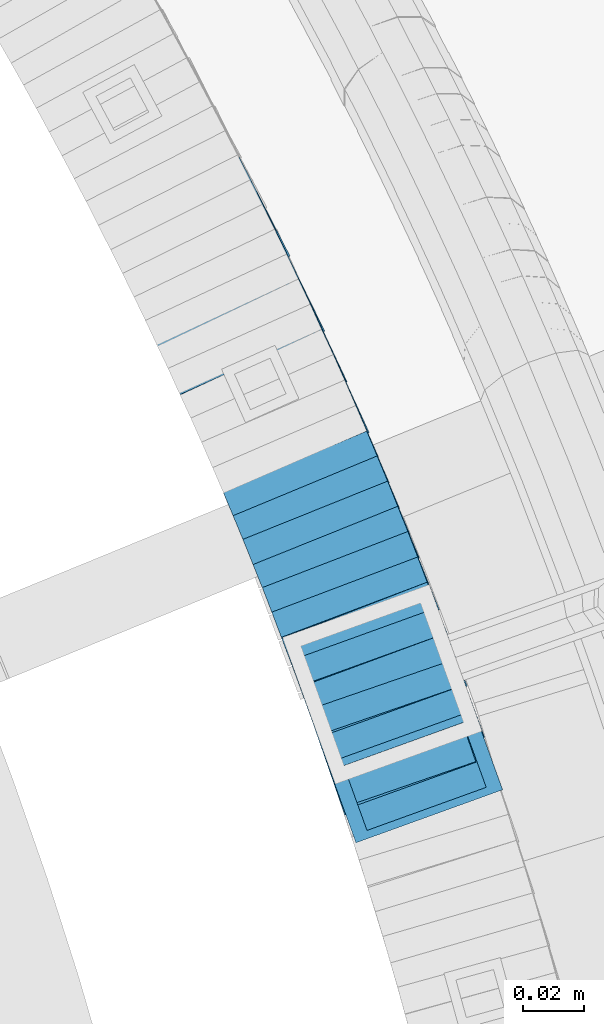
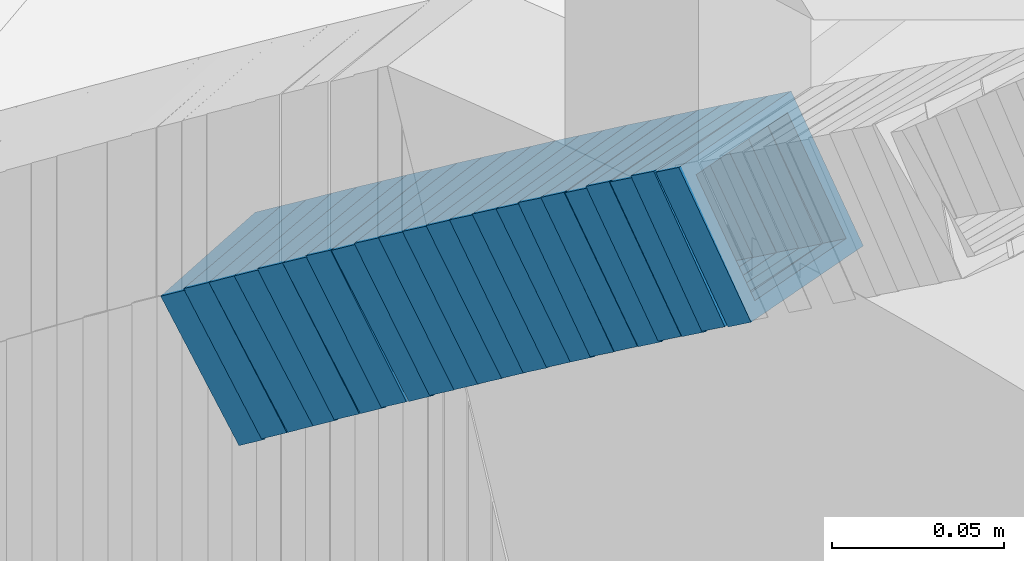
# One storey, part 800 of 975: 22 members.
"""IFC2X3 building model written with IfcOpenShell, lengths in millimetres."""

from ifc_helpers import new_model, si_unit, frame, origin_with_axes, place, context, subcontext, project, spatial, faceted_brep, material, type_object, element, save


model = new_model("IFC2X3")

# Units and contexts
model_context = context("Model", 3, precision=1e-05, world=origin_with_axes())
body_context = subcontext(model_context, "Body", "Model", "MODEL_VIEW")
ifc_project = project(units=[si_unit("LENGTHUNIT", "METRE", prefix="MILLI"), si_unit("AREAUNIT", "SQUARE_METRE"), si_unit("VOLUMEUNIT", "CUBIC_METRE"), si_unit("MASSUNIT", "GRAM", prefix="KILO"), si_unit("TIMEUNIT", "SECOND"), si_unit("PLANEANGLEUNIT", "RADIAN"), si_unit("SOLIDANGLEUNIT", "STERADIAN"), si_unit("THERMODYNAMICTEMPERATUREUNIT", "DEGREE_CELSIUS"), si_unit("LUMINOUSINTENSITYUNIT", "LUMEN")], contexts=[model_context])

# Site, building, storey
site_placement = place(None, origin_with_axes())
site = spatial("IfcSite", under=ifc_project, at=site_placement, CompositionType="ELEMENT")
building_placement = place(site_placement, origin_with_axes())
building = spatial("IfcBuilding", under=site, at=building_placement, Name="Undefined", CompositionType="ELEMENT")
storey_placement = place(building_placement, origin_with_axes())
storey = spatial("IfcBuildingStorey", under=building, at=storey_placement, Name="Undefined", CompositionType="ELEMENT", Elevation=0.0)

# Members
ifc_material = material()
member_type = type_object("IfcMemberType", Name="HSS2X2X.188_TUBES", PredefinedType="NOTDEFINED")
member_1_placement = place(storey_placement, frame((36056.3723395032, 3855.56364250104, 2169.06319573244), z_axis=(0.940453312518291, 0.339922883862463, 1.97324879991356e-10), x_axis=(0.285545985945671, -0.790010561850313, 0.542537373897198)))
element("IfcMember", 1, at=member_1_placement, inside=storey, type_object=member_type, material=ifc_material, Name="WALL", ObjectType="HSS2X2X.188_TUBES", context=body_context, shape_type="Brep", body=[
    faceted_brep([(0.0, 20.6374999999753, -20.6375000000298), (0.0, -20.6375000000153, -20.6375000000153), (10.5118980208099, -20.6374999999875, -20.637499999968), (10.5118980207899, 20.6374999999921, -20.6375000000189), (0.0, -20.6374999999825, 20.6375000000335), (10.5118980208281, -20.6374999999784, 20.637500000099), (0.0, 20.6375000000116, 20.6375000000189), (10.5118980208063, 20.6375000000016, 20.6375000000335), (0.0, 25.3999999999724, -25.4000000000342), (0.0, 25.400000000016, 25.4000000000196), (10.5118980208063, 25.4000000000005, 25.4000000000306), (10.5118980207862, 25.3999999999896, -25.4000000000378), (0.0, -25.399999999976, 25.4000000000378), (10.5118980208317, -25.3999999999746, 25.4000000001033), (0.0, -25.400000000016, -25.4000000000196), (10.5118980208135, -25.3999999999855, -25.3999999999724)], [[[0, 1, 2, 3]], [[1, 4, 5, 2]], [[4, 6, 7, 5]], [[6, 0, 3, 7]], [[8, 9, 10, 11]], [[9, 12, 13, 10]], [[12, 14, 15, 13]], [[14, 8, 11, 15]], [[13, 15, 11, 10], [5, 7, 3, 2]], [[14, 12, 9, 8], [6, 4, 1, 0]]]),
])
member_2_placement = place(storey_placement, frame((36050.4690767219, 3872.36681990624, 2157.57332488823), z_axis=(0.938152292840694, 0.346222869605329, 2.00598151423037e-10), x_axis=(0.292063186936097, -0.79139702382609, 0.537019408881968)))
element("IfcMember", 2, at=member_2_placement, inside=storey, type_object=member_type, material=ifc_material, Name="WALL", ObjectType="HSS2X2X.188_TUBES", context=body_context, shape_type="Brep", body=[
    faceted_brep([(0.0, 20.6374999999753, -20.6375000000298), (0.0, -20.6375000000153, -20.6375000000153), (10.6061303028146, -20.6374999999571, -20.6374999999643), (10.6061303027491, 20.6374999999971, -20.6375000000007), (0.0, -20.6374999999825, 20.6375000000335), (10.6061303027855, -20.6374999999825, 20.6375000000116), (0.0, 20.6375000000116, 20.6375000000189), (10.6061303027236, 20.637499999968, 20.6374999999716), (0.0, 25.3999999999724, -25.4000000000342), (0.0, 25.400000000016, 25.4000000000196), (10.6061303027163, 25.3999999999651, 25.3999999999651), (10.6061303027454, 25.3999999999942, -25.4000000000051), (0.0, -25.399999999976, 25.4000000000378), (10.6061303027891, -25.3999999999796, 25.4000000000124), (0.0, -25.400000000016, -25.4000000000196), (10.6061303028182, -25.3999999999505, -25.3999999999542)], [[[0, 1, 2, 3]], [[1, 4, 5, 2]], [[4, 6, 7, 5]], [[6, 0, 3, 7]], [[8, 9, 10, 11]], [[9, 12, 13, 10]], [[12, 14, 15, 13]], [[14, 8, 11, 15]], [[13, 15, 11, 10], [5, 7, 3, 2]], [[14, 12, 9, 8], [6, 4, 1, 0]]]),
])
member_3_placement = place(storey_placement, frame((36053.1413653361, 3864.30582773632, 2163.32011987454), z_axis=(0.945253332455169, 0.326337459514532, 3.89617525797802e-10), x_axis=(0.274687234983439, -0.795645785953005, 0.53990249696809)))
element("IfcMember", 3, at=member_3_placement, inside=storey, type_object=member_type, material=ifc_material, Name="WALL", ObjectType="HSS2X2X.188_TUBES", context=body_context, shape_type="Brep", body=[
    faceted_brep([(0.0, 20.6374999999753, -20.6375000000298), (0.0, -20.6375000000153, -20.6375000000153), (10.5550935571373, -20.6374999999935, -20.6374999999753), (10.5550935571373, 20.6375000000025, -20.6374999999862), (0.0, -20.6374999999825, 20.6375000000335), (10.5550935571027, -20.6374999999989, 20.6374999999862), (0.0, 20.6375000000116, 20.6375000000189), (10.5550935571027, 20.6374999999953, 20.6374999999716), (0.0, 25.3999999999724, -25.4000000000342), (0.0, 25.400000000016, 25.4000000000196), (10.5550935570991, 25.3999999999924, 25.3999999999651), (10.5550935571373, 25.3999999999996, -25.3999999999905), (0.0, -25.399999999976, 25.4000000000378), (10.5550935571009, -25.3999999999996, 25.3999999999833), (0.0, -25.400000000016, -25.4000000000196), (10.5550935571428, -25.3999999999905, -25.3999999999724)], [[[0, 1, 2, 3]], [[1, 4, 5, 2]], [[4, 6, 7, 5]], [[6, 0, 3, 7]], [[8, 9, 10, 11]], [[9, 12, 13, 10]], [[12, 14, 15, 13]], [[14, 8, 11, 15]], [[13, 15, 11, 10], [5, 7, 3, 2]], [[14, 12, 9, 8], [6, 4, 1, 0]]]),
])
member_4_placement = place(storey_placement, frame((36047.3723395032, 3880.66364250103, 2151.96319573233), z_axis=(0.940453312518291, 0.339922883862463, 1.97324879991356e-10), x_axis=(0.285545985945671, -0.790010561850313, 0.542537373897198)))
element("IfcMember", 4, at=member_4_placement, inside=storey, type_object=member_type, material=ifc_material, Name="WALL", ObjectType="HSS2X2X.188_TUBES", context=body_context, shape_type="Brep", body=[
    faceted_brep([(0.0, 20.6374999999753, -20.6375000000298), (0.0, -20.6375000000153, -20.6375000000153), (10.5118980208099, -20.6374999999875, -20.637499999968), (10.5118980207899, 20.6374999999921, -20.6375000000189), (0.0, -20.6374999999825, 20.6375000000335), (10.5118980208281, -20.6374999999784, 20.637500000099), (0.0, 20.6375000000116, 20.6375000000189), (10.5118980208063, 20.6375000000016, 20.6375000000335), (0.0, 25.3999999999724, -25.4000000000342), (0.0, 25.400000000016, 25.4000000000196), (10.5118980208063, 25.4000000000005, 25.4000000000306), (10.5118980207862, 25.3999999999896, -25.4000000000378), (0.0, -25.399999999976, 25.4000000000378), (10.5118980208317, -25.3999999999746, 25.4000000001033), (0.0, -25.400000000016, -25.4000000000196), (10.5118980208135, -25.3999999999855, -25.3999999999724)], [[[0, 1, 2, 3]], [[1, 4, 5, 2]], [[4, 6, 7, 5]], [[6, 0, 3, 7]], [[8, 9, 10, 11]], [[9, 12, 13, 10]], [[12, 14, 15, 13]], [[14, 8, 11, 15]], [[13, 15, 11, 10], [5, 7, 3, 2]], [[14, 12, 9, 8], [6, 4, 1, 0]]]),
])
member_5_placement = place(storey_placement, frame((36044.6056120165, 3888.63404795882, 2146.2138164465), z_axis=(0.933055569354949, 0.359732267798863, 2.02075170818717e-10), x_axis=(0.302885839104442, -0.785610145271108, 0.5395154011862)))
element("IfcMember", 5, at=member_5_placement, inside=storey, type_object=member_type, material=ifc_material, Name="WALL", ObjectType="HSS2X2X.188_TUBES", context=body_context, shape_type="Brep", body=[
    faceted_brep([(0.0, 20.6374999999753, -20.6375000000298), (0.0, -20.6375000000153, -20.6375000000153), (10.5744976239494, -20.6375000000207, -20.6375000000335), (10.5744976239657, 20.6375000000098, -20.637500000008), (0.0, -20.6374999999825, 20.6375000000335), (10.5744976239639, -20.6375000000244, 20.6374999999753), (0.0, 20.6375000000116, 20.6375000000189), (10.5744976239803, 20.6374999999989, 20.6374999999935), (0.0, 25.3999999999724, -25.4000000000342), (0.0, 25.400000000016, 25.4000000000196), (10.5744976239857, 25.4000000000051, 25.4000000000015), (10.5744976239675, 25.4000000000124, -25.4000000000051), (0.0, -25.399999999976, 25.4000000000378), (10.5744976239639, -25.4000000000287, 25.3999999999724), (0.0, -25.400000000016, -25.4000000000196), (10.5744976239494, -25.4000000000215, -25.4000000000378)], [[[0, 1, 2, 3]], [[1, 4, 5, 2]], [[4, 6, 7, 5]], [[6, 0, 3, 7]], [[8, 9, 10, 11]], [[9, 12, 13, 10]], [[12, 14, 15, 13]], [[14, 8, 11, 15]], [[13, 15, 11, 10], [5, 7, 3, 2]], [[14, 12, 9, 8], [6, 4, 1, 0]]]),
])
member_6_placement = place(storey_placement, frame((36038.2438297402, 3905.29429573805, 2134.80473457044), z_axis=(0.933055569354949, 0.359732267798863, 2.02075170818717e-10), x_axis=(0.304430731987314, -0.789617209966803, 0.532753780977583)))
element("IfcMember", 6, at=member_6_placement, inside=storey, type_object=member_type, material=ifc_material, Name="WALL", ObjectType="HSS2X2X.188_TUBES", context=body_context, shape_type="Brep", body=[
    faceted_brep([(0.0, 20.6374999999753, -20.6375000000298), (0.0, -20.6375000000153, -20.6375000000153), (10.5118980208099, -20.6374999999875, -20.637499999968), (10.5118980207899, 20.6374999999921, -20.6375000000189), (0.0, -20.6374999999825, 20.6375000000335), (10.5118980208281, -20.6374999999784, 20.637500000099), (0.0, 20.6375000000116, 20.6375000000189), (10.5118980208063, 20.6375000000016, 20.6375000000335), (0.0, 25.3999999999724, -25.4000000000342), (0.0, 25.400000000016, 25.4000000000196), (10.5118980208063, 25.4000000000005, 25.4000000000306), (10.5118980207862, 25.3999999999896, -25.4000000000378), (0.0, -25.399999999976, 25.4000000000378), (10.5118980208317, -25.3999999999746, 25.4000000001033), (0.0, -25.400000000016, -25.4000000000196), (10.5118980208135, -25.3999999999855, -25.3999999999724)], [[[0, 1, 2, 3]], [[1, 4, 5, 2]], [[4, 6, 7, 5]], [[6, 0, 3, 7]], [[8, 9, 10, 11]], [[9, 12, 13, 10]], [[12, 14, 15, 13]], [[14, 8, 11, 15]], [[13, 15, 11, 10], [5, 7, 3, 2]], [[14, 12, 9, 8], [6, 4, 1, 0]]]),
])
member_7_placement = place(storey_placement, frame((36035.3513403643, 3913.00453572634, 2129.25354307798), z_axis=(0.927694411235425, 0.373340433602575, 2.94433448289055e-10), x_axis=(0.313759664807495, -0.779645228521997, 0.541948512667736)))
element("IfcMember", 7, at=member_7_placement, inside=storey, type_object=member_type, material=ifc_material, Name="WALL", ObjectType="HSS2X2X.188_TUBES", context=body_context, shape_type="Brep", body=[
    faceted_brep([(0.0, 20.6374999999753, -20.6375000000298), (0.0, -20.6375000000153, -20.6375000000153), (10.5190303735253, -20.6375000000171, -20.6375000000444), (10.5190303734962, 20.6374999999607, -20.6375000000808), (0.0, -20.6374999999825, 20.6375000000335), (10.5190303735744, -20.6374999999844, 20.6375000000407), (0.0, 20.6375000000116, 20.6375000000189), (10.5190303735435, 20.6374999999916, 20.6375000000044), (0.0, 25.3999999999724, -25.4000000000342), (0.0, 25.400000000016, 25.4000000000196), (10.5190303735435, 25.3999999999942, 25.4000000000124), (10.5190303734835, 25.3999999999523, -25.4000000000924), (0.0, -25.399999999976, 25.4000000000378), (10.5190303735853, -25.399999999976, 25.400000000056), (0.0, -25.400000000016, -25.4000000000196), (10.5190303735235, -25.4000000000196, -25.4000000000451)], [[[0, 1, 2, 3]], [[1, 4, 5, 2]], [[4, 6, 7, 5]], [[6, 0, 3, 7]], [[8, 9, 10, 11]], [[9, 12, 13, 10]], [[12, 14, 15, 13]], [[14, 8, 11, 15]], [[13, 15, 11, 10], [5, 7, 3, 2]], [[14, 12, 9, 8], [6, 4, 1, 0]]]),
])
member_8_placement = place(storey_placement, frame((36041.4128976851, 3896.82431602697, 2140.60556520589), z_axis=(0.935388263671988, 0.353622392086111, -1.27792191051413e-10), x_axis=(0.296464132970014, -0.78419544892014, 0.545111470944502)))
element("IfcMember", 8, at=member_8_placement, inside=storey, type_object=member_type, material=ifc_material, Name="WALL", ObjectType="HSS2X2X.188_TUBES", context=body_context, shape_type="Brep", body=[
    faceted_brep([(0.0, 20.6374999999753, -20.6375000000298), (0.0, -20.6375000000153, -20.6375000000153), (10.4565768777284, -20.6375000000116, -20.6375000000407), (10.456576877752, 20.6375000000007, -20.6374999999971), (0.0, -20.6374999999825, 20.6375000000335), (10.4565768777265, -20.6375000000126, 20.6374999999389), (0.0, 20.6375000000116, 20.6375000000189), (10.4565768777502, 20.6374999999989, 20.6374999999825), (0.0, 25.3999999999724, -25.4000000000342), (0.0, 25.400000000016, 25.4000000000196), (10.456576877752, 25.3999999999992, 25.3999999999796), (10.4565768777538, 25.4000000000015, -25.3999999999942), (0.0, -25.399999999976, 25.4000000000378), (10.4565768777247, -25.4000000000142, 25.399999999936), (0.0, -25.400000000016, -25.4000000000196), (10.4565768777265, -25.4000000000115, -25.4000000000451)], [[[0, 1, 2, 3]], [[1, 4, 5, 2]], [[4, 6, 7, 5]], [[6, 0, 3, 7]], [[8, 9, 10, 11]], [[9, 12, 13, 10]], [[12, 14, 15, 13]], [[14, 8, 11, 15]], [[13, 15, 11, 10], [5, 7, 3, 2]], [[14, 12, 9, 8], [6, 4, 1, 0]]]),
])
member_9_placement = place(storey_placement, frame((36028.8032098126, 3929.41023413412, 2117.81749797898), z_axis=(0.923742113500945, 0.383015022870914, -4.53592292615214e-11), x_axis=(0.323941772034664, -0.781271332083476, 0.533551154056996)))
element("IfcMember", 9, at=member_9_placement, inside=storey, type_object=member_type, material=ifc_material, Name="WALL", ObjectType="HSS2X2X.188_TUBES", context=body_context, shape_type="Brep", body=[
    faceted_brep([(0.0, 20.6374999999753, -20.6375000000298), (0.0, -20.6375000000153, -20.6375000000153), (10.5019045891313, -20.6375000000226, -20.6375000000371), (10.5019045891022, 20.6374999999662, -20.6375000000771), (0.0, -20.6374999999825, 20.6375000000335), (10.5019045891859, -20.6374999999771, 20.6375000000444), (0.0, 20.6375000000116, 20.6375000000189), (10.5019045891568, 20.6375000000098, 20.637500000008), (0.0, 25.3999999999724, -25.4000000000342), (0.0, 25.400000000016, 25.4000000000196), (10.5019045891586, 25.4000000000106, 25.400000000016), (10.5019045890895, 25.399999999956, -25.4000000000851), (0.0, -25.399999999976, 25.4000000000378), (10.501904589195, -25.3999999999669, 25.4000000000597), (0.0, -25.400000000016, -25.4000000000196), (10.5019045891258, -25.4000000000269, -25.4000000000451)], [[[0, 1, 2, 3]], [[1, 4, 5, 2]], [[4, 6, 7, 5]], [[6, 0, 3, 7]], [[8, 9, 10, 11]], [[9, 12, 13, 10]], [[12, 14, 15, 13]], [[14, 8, 11, 15]], [[13, 15, 11, 10], [5, 7, 3, 2]], [[14, 12, 9, 8], [6, 4, 1, 0]]]),
])
member_10_placement = place(storey_placement, frame((36025.6062053644, 3937.17867082729, 2112.29243384252), z_axis=(0.922063368293112, 0.387038944877595, 1.46842921822099e-10), x_axis=(0.324679446004751, -0.773501033011783, 0.544315542008267)))
element("IfcMember", 10, at=member_10_placement, inside=storey, type_object=member_type, material=ifc_material, Name="WALL", ObjectType="HSS2X2X.188_TUBES", context=body_context, shape_type="Brep", body=[
    faceted_brep([(0.0, 20.6374999999753, -20.6375000000298), (0.0, -20.6375000000153, -20.6375000000153), (10.4737767782171, -20.6374999999939, -20.637499999968), (10.4737767782117, 20.6374999999989, -20.6374999999753), (0.0, -20.6374999999825, 20.6375000000335), (10.4737767782153, -20.6374999999975, 20.6375000000116), (0.0, 20.6375000000116, 20.6375000000189), (10.4737767782062, 20.6374999999944, 20.6375000000044), (0.0, 25.3999999999724, -25.4000000000342), (0.0, 25.400000000016, 25.4000000000196), (10.4737767782062, 25.3999999999933, 25.4000000000015), (10.4737767782099, 25.3999999999992, -25.3999999999796), (0.0, -25.399999999976, 25.4000000000378), (10.4737767782117, -25.3999999999983, 25.400000000016), (0.0, -25.400000000016, -25.4000000000196), (10.473776778219, -25.3999999999924, -25.3999999999578)], [[[0, 1, 2, 3]], [[1, 4, 5, 2]], [[4, 6, 7, 5]], [[6, 0, 3, 7]], [[8, 9, 10, 11]], [[9, 12, 13, 10]], [[12, 14, 15, 13]], [[14, 8, 11, 15]], [[13, 15, 11, 10], [5, 7, 3, 2]], [[14, 12, 9, 8], [6, 4, 1, 0]]]),
])
member_11_placement = place(storey_placement, frame((36022.1855073996, 3945.40305652041, 2106.49970632867), z_axis=(0.919724178958997, 0.392565197945765, 2.16004991671071e-11), x_axis=(0.330748445965165, -0.774896359918632, 0.538647469943453)))
element("IfcMember", 11, at=member_11_placement, inside=storey, type_object=member_type, material=ifc_material, Name="WALL", ObjectType="HSS2X2X.188_TUBES", context=body_context, shape_type="Brep", body=[
    faceted_brep([(0.0, 20.6374999999753, -20.6375000000298), (0.0, -20.6375000000153, -20.6375000000153), (10.5806427026419, -20.6374999999607, -20.6374999999316), (10.5806427026473, 20.6375000000444, -20.6374999999207), (0.0, -20.6374999999825, 20.6375000000335), (10.5806427025509, -20.6375000000207, 20.6374999999643), (0.0, 20.6375000000116, 20.6375000000189), (10.5806427025545, 20.6374999999862, 20.6374999999716), (0.0, 25.3999999999724, -25.4000000000342), (0.0, 25.400000000016, 25.4000000000196), (10.5806427025436, 25.3999999999796, 25.3999999999614), (10.5806427026582, 25.4000000000542, -25.3999999999105), (0.0, -25.399999999976, 25.4000000000378), (10.5806427025418, -25.4000000000287, 25.3999999999542), (0.0, -25.400000000016, -25.4000000000196), (10.5806427026528, -25.3999999999542, -25.3999999999178)], [[[0, 1, 2, 3]], [[1, 4, 5, 2]], [[4, 6, 7, 5]], [[6, 0, 3, 7]], [[8, 9, 10, 11]], [[9, 12, 13, 10]], [[12, 14, 15, 13]], [[14, 8, 11, 15]], [[13, 15, 11, 10], [5, 7, 3, 2]], [[14, 12, 9, 8], [6, 4, 1, 0]]]),
])
member_12_placement = place(storey_placement, frame((36032.0513403643, 3921.20453572631, 2123.55354307795), z_axis=(0.927694411235425, 0.373340433602575, 2.94433448289055e-10), x_axis=(0.313759664807495, -0.779645228521997, 0.541948512667736)))
element("IfcMember", 12, at=member_12_placement, inside=storey, type_object=member_type, material=ifc_material, Name="WALL", ObjectType="HSS2X2X.188_TUBES", context=body_context, shape_type="Brep", body=[
    faceted_brep([(0.0, 20.6374999999753, -20.6375000000298), (0.0, -20.6375000000153, -20.6375000000153), (10.5190303735253, -20.6375000000171, -20.6375000000444), (10.5190303734962, 20.6374999999607, -20.6375000000808), (0.0, -20.6374999999825, 20.6375000000335), (10.5190303735744, -20.6374999999844, 20.6375000000407), (0.0, 20.6375000000116, 20.6375000000189), (10.5190303735435, 20.6374999999916, 20.6375000000044), (0.0, 25.3999999999724, -25.4000000000342), (0.0, 25.400000000016, 25.4000000000196), (10.5190303735435, 25.3999999999942, 25.4000000000124), (10.5190303734835, 25.3999999999523, -25.4000000000924), (0.0, -25.399999999976, 25.4000000000378), (10.5190303735853, -25.399999999976, 25.400000000056), (0.0, -25.400000000016, -25.4000000000196), (10.5190303735235, -25.4000000000196, -25.4000000000451)], [[[0, 1, 2, 3]], [[1, 4, 5, 2]], [[4, 6, 7, 5]], [[6, 0, 3, 7]], [[8, 9, 10, 11]], [[9, 12, 13, 10]], [[12, 14, 15, 13]], [[14, 8, 11, 15]], [[13, 15, 11, 10], [5, 7, 3, 2]], [[14, 12, 9, 8], [6, 4, 1, 0]]]),
])
member_13_placement = place(storey_placement, frame((36018.7279145436, 3953.57398982548, 2100.71689013174), z_axis=(0.917421155215159, 0.39791760951695, -2.49158347287448e-10), x_axis=(0.334988817978852, -0.772335329951652, 0.539704205966199)))
element("IfcMember", 13, at=member_13_placement, inside=storey, type_object=member_type, material=ifc_material, Name="WALL", ObjectType="HSS2X2X.188_TUBES", context=body_context, shape_type="Brep", body=[
    faceted_brep([(0.0, 20.6374999999753, -20.6375000000298), (0.0, -20.6375000000153, -20.6375000000153), (10.7466273779264, -20.6375000000044, -20.6374999999753), (10.746627377941, 20.6375000000298, -20.6374999999352), (0.0, -20.6374999999825, 20.6375000000335), (10.7466273778828, -20.6375000000189, 20.6374999999425), (0.0, 20.6375000000116, 20.6375000000189), (10.7466273778973, 20.6375000000153, 20.6374999999825), (0.0, 25.3999999999724, -25.4000000000342), (0.0, 25.400000000016, 25.4000000000196), (10.7466273778919, 25.4000000000142, 25.3999999999724), (10.7466273779501, 25.4000000000342, -25.3999999999178), (0.0, -25.399999999976, 25.4000000000378), (10.7466273778737, -25.4000000000233, 25.3999999999251), (0.0, -25.400000000016, -25.4000000000196), (10.7466273779319, -25.4000000000033, -25.3999999999651)], [[[0, 1, 2, 3]], [[1, 4, 5, 2]], [[4, 6, 7, 5]], [[6, 0, 3, 7]], [[8, 9, 10, 11]], [[9, 12, 13, 10]], [[12, 14, 15, 13]], [[14, 8, 11, 15]], [[13, 15, 11, 10], [5, 7, 3, 2]], [[14, 12, 9, 8], [6, 4, 1, 0]]]),
])
member_14_placement = place(storey_placement, frame((36015.200737512, 3961.75901511221, 2094.97216907695), z_axis=(0.915644030049762, 0.401990062357556, -1.95650045498041e-10), x_axis=(0.339125003999153, -0.772451396997912, 0.536947921998538)))
element("IfcMember", 14, at=member_14_placement, inside=storey, type_object=member_type, material=ifc_material, Name="WALL", ObjectType="HSS2X2X.188_TUBES", context=body_context, shape_type="Brep", body=[
    faceted_brep([(0.0, 20.6374999999753, -20.6375000000298), (0.0, -20.6375000000153, -20.6375000000153), (10.6216759506497, -20.637499999968, -20.6374999999534), (10.6216759506497, 20.6375000000262, -20.6374999999643), (0.0, -20.6374999999825, 20.6375000000335), (10.6216759506169, -20.6374999999935, 20.637500000008), (0.0, 20.6375000000116, 20.6375000000189), (10.6216759506242, 20.6375000000007, 20.6374999999971), (0.0, 25.3999999999724, -25.4000000000342), (0.0, 25.400000000016, 25.4000000000196), (10.6216759506169, 25.3999999999978, 25.3999999999869), (10.6216759506533, 25.4000000000269, -25.3999999999614), (0.0, -25.399999999976, 25.4000000000378), (10.6216759506242, -25.3999999999942, 25.4000000000051), (0.0, -25.400000000016, -25.4000000000196), (10.6216759506569, -25.3999999999614, -25.3999999999432)], [[[0, 1, 2, 3]], [[1, 4, 5, 2]], [[4, 6, 7, 5]], [[6, 0, 3, 7]], [[8, 9, 10, 11]], [[9, 12, 13, 10]], [[12, 14, 15, 13]], [[14, 8, 11, 15]], [[13, 15, 11, 10], [5, 7, 3, 2]], [[14, 12, 9, 8], [6, 4, 1, 0]]]),
])
member_15_placement = place(storey_placement, frame((36011.9315722985, 3969.39483370138, 2089.31633482609), z_axis=(0.909595755817756, 0.415494357360392, 3.29607246385422e-10), x_axis=(0.348159164869234, -0.762186280713586, 0.545763015794904)))
element("IfcMember", 15, at=member_15_placement, inside=storey, type_object=member_type, material=ifc_material, Name="WALL", ObjectType="HSS2X2X.188_TUBES", context=body_context, shape_type="Brep", body=[
    faceted_brep([(0.0, 20.6374999999753, -20.6375000000298), (0.0, -20.6375000000153, -20.6375000000153), (10.6348483769107, -20.637499999988, -20.6374999999825), (10.6348483768415, 20.6374999999734, -20.6375000001026), (0.0, -20.6374999999825, 20.6375000000335), (10.6348483769852, -20.6374999999589, 20.6375000001462), (0.0, 20.6375000000116, 20.6375000000189), (10.6348483769161, 20.6375000000044, 20.6375000000226), (0.0, 25.3999999999724, -25.4000000000342), (0.0, 25.400000000016, 25.4000000000196), (10.6348483769179, 25.4000000000015, 25.4000000000233), (10.6348483768288, 25.3999999999669, -25.4000000001324), (0.0, -25.399999999976, 25.4000000000378), (10.6348483769998, -25.3999999999505, 25.4000000001688), (0.0, -25.400000000016, -25.4000000000196), (10.6348483769107, -25.3999999999887, -25.3999999999833)], [[[0, 1, 2, 3]], [[1, 4, 5, 2]], [[4, 6, 7, 5]], [[6, 0, 3, 7]], [[8, 9, 10, 11]], [[9, 12, 13, 10]], [[12, 14, 15, 13]], [[14, 8, 11, 15]], [[13, 15, 11, 10], [5, 7, 3, 2]], [[14, 12, 9, 8], [6, 4, 1, 0]]]),
])
member_16_placement = place(storey_placement, frame((36004.6484982414, 3985.56116836209, 2077.7865747047), z_axis=(0.905324661295672, 0.424720211021181, 6.89760781824589e-11), x_axis=(0.356387499864382, -0.75966809271095, 0.543959868793023)))
element("IfcMember", 16, at=member_16_placement, inside=storey, type_object=member_type, material=ifc_material, Name="WALL", ObjectType="HSS2X2X.188_TUBES", context=body_context, shape_type="Brep", body=[
    faceted_brep([(0.0, 20.6374999999753, -20.6375000000298), (0.0, -20.6375000000153, -20.6375000000153), (10.6625512894789, -20.6374999999625, -20.6374999999389), (10.6625512893879, 20.6374999999789, -20.6375000000371), (0.0, -20.6374999999825, 20.6375000000335), (10.6625512894352, -20.6374999999989, 20.6375000000153), (0.0, 20.6375000000116, 20.6375000000189), (10.6625512893443, 20.6374999999443, 20.6374999999134), (0.0, 25.3999999999724, -25.4000000000342), (0.0, 25.400000000016, 25.4000000000196), (10.6625512893297, 25.3999999999342, 25.3999999998996), (10.6625512893916, 25.399999999976, -25.4000000000415), (0.0, -25.399999999976, 25.4000000000378), (10.6625512894389, -25.399999999996, 25.400000000016), (0.0, -25.400000000016, -25.4000000000196), (10.6625512894971, -25.3999999999523, -25.3999999999214)], [[[0, 1, 2, 3]], [[1, 4, 5, 2]], [[4, 6, 7, 5]], [[6, 0, 3, 7]], [[8, 9, 10, 11]], [[9, 12, 13, 10]], [[12, 14, 15, 13]], [[14, 8, 11, 15]], [[13, 15, 11, 10], [5, 7, 3, 2]], [[14, 12, 9, 8], [6, 4, 1, 0]]]),
])
member_17_placement = place(storey_placement, frame((36008.014608229, 3977.91934562901, 2083.44425174195), z_axis=(0.911505056464486, 0.411288866904605, 1.76136381924153e-10), x_axis=(0.347421669115937, -0.769961537257535, 0.535217166179029)))
element("IfcMember", 17, at=member_17_placement, inside=storey, type_object=member_type, material=ifc_material, Name="WALL", ObjectType="HSS2X2X.188_TUBES", context=body_context, shape_type="Brep", body=[
    faceted_brep([(0.0, 20.6374999999753, -20.6375000000298), (0.0, -20.6375000000153, -20.6375000000153), (10.648004507897, -20.6374999999862, -20.637499999968), (10.6480045078188, 20.6374999999771, -20.6375000000808), (0.0, -20.6374999999825, 20.6375000000335), (10.6480045079406, -20.6374999999698, 20.6375000001062), (0.0, 20.6375000000116, 20.6375000000189), (10.6480045078679, 20.6374999999935, 20.6375000000007), (0.0, 25.3999999999724, -25.4000000000342), (0.0, 25.400000000016, 25.4000000000196), (10.6480045078661, 25.3999999999905, 25.4000000000015), (10.648004507806, 25.3999999999705, -25.4000000000997), (0.0, -25.399999999976, 25.4000000000378), (10.6480045079552, -25.3999999999633, 25.4000000001288), (0.0, -25.400000000016, -25.4000000000196), (10.6480045078988, -25.3999999999814, -25.3999999999651)], [[[0, 1, 2, 3]], [[1, 4, 5, 2]], [[4, 6, 7, 5]], [[6, 0, 3, 7]], [[8, 9, 10, 11]], [[9, 12, 13, 10]], [[12, 14, 15, 13]], [[14, 8, 11, 15]], [[13, 15, 11, 10], [5, 7, 3, 2]], [[14, 12, 9, 8], [6, 4, 1, 0]]]),
])
member_18_placement = place(storey_placement, frame((36000.776713144, 3993.81418396453, 2071.97795491846), z_axis=(0.905324661295672, 0.424720211021181, 6.89760781824589e-11), x_axis=(0.358203761111467, -0.763539595237563, 0.537305641167165)))
element("IfcMember", 18, at=member_18_placement, inside=storey, type_object=member_type, material=ifc_material, Name="WALL", ObjectType="HSS2X2X.188_TUBES", context=body_context, shape_type="Brep", body=[
    faceted_brep([(0.0, 20.6374999999753, -20.6375000000298), (0.0, -20.6375000000153, -20.6375000000153), (10.6061303028146, -20.6374999999571, -20.6374999999643), (10.6061303027491, 20.6374999999971, -20.6375000000007), (0.0, -20.6374999999825, 20.6375000000335), (10.6061303027855, -20.6374999999825, 20.6375000000116), (0.0, 20.6375000000116, 20.6375000000189), (10.6061303027236, 20.637499999968, 20.6374999999716), (0.0, 25.3999999999724, -25.4000000000342), (0.0, 25.400000000016, 25.4000000000196), (10.6061303027163, 25.3999999999651, 25.3999999999651), (10.6061303027454, 25.3999999999942, -25.4000000000051), (0.0, -25.399999999976, 25.4000000000378), (10.6061303027891, -25.3999999999796, 25.4000000000124), (0.0, -25.400000000016, -25.4000000000196), (10.6061303028182, -25.3999999999505, -25.3999999999542)], [[[0, 1, 2, 3]], [[1, 4, 5, 2]], [[4, 6, 7, 5]], [[6, 0, 3, 7]], [[8, 9, 10, 11]], [[9, 12, 13, 10]], [[12, 14, 15, 13]], [[14, 8, 11, 15]], [[13, 15, 11, 10], [5, 7, 3, 2]], [[14, 12, 9, 8], [6, 4, 1, 0]]]),
])
member_19_placement = place(storey_placement, frame((35997.2469403871, 4001.51370306505, 2066.31067219846), z_axis=(0.898876404534364, 0.438202247108996, 8.72196324053222e-11), x_axis=(0.369009902076277, -0.756943389157102, 0.539322165111927)))
element("IfcMember", 19, at=member_19_placement, inside=storey, type_object=member_type, material=ifc_material, Name="WALL", ObjectType="HSS2X2X.188_TUBES", context=body_context, shape_type="Brep", body=[
    faceted_brep([(0.0, 20.6374999999753, -20.6375000000298), (0.0, -20.6375000000153, -20.6375000000153), (10.5744976239494, -20.6375000000207, -20.6375000000335), (10.5744976239657, 20.6375000000098, -20.637500000008), (0.0, -20.6374999999825, 20.6375000000335), (10.5744976239639, -20.6375000000244, 20.6374999999753), (0.0, 20.6375000000116, 20.6375000000189), (10.5744976239803, 20.6374999999989, 20.6374999999935), (0.0, 25.3999999999724, -25.4000000000342), (0.0, 25.400000000016, 25.4000000000196), (10.5744976239857, 25.4000000000051, 25.4000000000015), (10.5744976239675, 25.4000000000124, -25.4000000000051), (0.0, -25.399999999976, 25.4000000000378), (10.5744976239639, -25.4000000000287, 25.3999999999724), (0.0, -25.400000000016, -25.4000000000196), (10.5744976239494, -25.4000000000215, -25.4000000000378)], [[[0, 1, 2, 3]], [[1, 4, 5, 2]], [[4, 6, 7, 5]], [[6, 0, 3, 7]], [[8, 9, 10, 11]], [[9, 12, 13, 10]], [[12, 14, 15, 13]], [[14, 8, 11, 15]], [[13, 15, 11, 10], [5, 7, 3, 2]], [[14, 12, 9, 8], [6, 4, 1, 0]]]),
])
member_20_placement = place(storey_placement, frame((35993.4210510205, 4009.36168125312, 2060.61993544273), z_axis=(0.898876404534364, 0.438202247108996, 8.72196324053222e-11), x_axis=(0.367124886937046, -0.75307668987023, 0.545980600905892)))
element("IfcMember", 20, at=member_20_placement, inside=storey, type_object=member_type, material=ifc_material, Name="WALL", ObjectType="HSS2X2X.188_TUBES", context=body_context, shape_type="Brep", body=[
    faceted_brep([(0.0, 20.6374999999753, -20.6375000000298), (0.0, -20.6375000000153, -20.6375000000153), (10.6216759506497, -20.637499999968, -20.6374999999534), (10.6216759506497, 20.6375000000262, -20.6374999999643), (0.0, -20.6374999999825, 20.6375000000335), (10.6216759506169, -20.6374999999935, 20.637500000008), (0.0, 20.6375000000116, 20.6375000000189), (10.6216759506242, 20.6375000000007, 20.6374999999971), (0.0, 25.3999999999724, -25.4000000000342), (0.0, 25.400000000016, 25.4000000000196), (10.6216759506169, 25.3999999999978, 25.3999999999869), (10.6216759506533, 25.4000000000269, -25.3999999999614), (0.0, -25.399999999976, 25.4000000000378), (10.6216759506242, -25.3999999999942, 25.4000000000051), (0.0, -25.400000000016, -25.4000000000196), (10.6216759506569, -25.3999999999614, -25.3999999999432)], [[[0, 1, 2, 3]], [[1, 4, 5, 2]], [[4, 6, 7, 5]], [[6, 0, 3, 7]], [[8, 9, 10, 11]], [[9, 12, 13, 10]], [[12, 14, 15, 13]], [[14, 8, 11, 15]], [[13, 15, 11, 10], [5, 7, 3, 2]], [[14, 12, 9, 8], [6, 4, 1, 0]]]),
])
member_21_placement = place(storey_placement, frame((35989.4469403871, 4017.51370306503, 2054.81067219838), z_axis=(0.898876404534364, 0.438202247108996, 8.72196324053222e-11), x_axis=(0.369009902076277, -0.756943389157102, 0.539322165111927)))
element("IfcMember", 21, at=member_21_placement, inside=storey, type_object=member_type, material=ifc_material, Name="WALL", ObjectType="HSS2X2X.188_TUBES", context=body_context, shape_type="Brep", body=[
    faceted_brep([(0.0, 20.6374999999753, -20.6375000000298), (0.0, -20.6375000000153, -20.6375000000153), (10.5744976239494, -20.6375000000207, -20.6375000000335), (10.5744976239657, 20.6375000000098, -20.637500000008), (0.0, -20.6374999999825, 20.6375000000335), (10.5744976239639, -20.6375000000244, 20.6374999999753), (0.0, 20.6375000000116, 20.6375000000189), (10.5744976239803, 20.6374999999989, 20.6374999999935), (0.0, 25.3999999999724, -25.4000000000342), (0.0, 25.400000000016, 25.4000000000196), (10.5744976239857, 25.4000000000051, 25.4000000000015), (10.5744976239675, 25.4000000000124, -25.4000000000051), (0.0, -25.399999999976, 25.4000000000378), (10.5744976239639, -25.4000000000287, 25.3999999999724), (0.0, -25.400000000016, -25.4000000000196), (10.5744976239494, -25.4000000000215, -25.4000000000378)], [[[0, 1, 2, 3]], [[1, 4, 5, 2]], [[4, 6, 7, 5]], [[6, 0, 3, 7]], [[8, 9, 10, 11]], [[9, 12, 13, 10]], [[12, 14, 15, 13]], [[14, 8, 11, 15]], [[13, 15, 11, 10], [5, 7, 3, 2]], [[14, 12, 9, 8], [6, 4, 1, 0]]]),
])
member_22_placement = place(storey_placement, frame((35985.7748751982, 4025.2682298963, 2049.04881370044), z_axis=(0.889933250590133, 0.456090790845507, -3.13543750962708e-11), x_axis=(0.38518458790159, -0.751579683808627, 0.535500524863615)))
element("IfcMember", 22, at=member_22_placement, inside=storey, type_object=member_type, material=ifc_material, Name="WALL", ObjectType="HSS2X2X.188_TUBES", context=body_context, shape_type="Brep", body=[
    faceted_brep([(0.0, 20.6374999999753, -20.6375000000298), (0.0, -20.6375000000153, -20.6375000000153), (10.6395488625676, -20.6374999999771, -20.6374999999716), (10.6395488625531, 20.6374999999916, -20.6375000000189), (0.0, -20.6374999999825, 20.6375000000335), (10.6395488625731, -20.6374999999844, 20.6375000000153), (0.0, 20.6375000000116, 20.6375000000189), (10.6395488625585, 20.6374999999825, 20.637499999968), (0.0, 25.3999999999724, -25.4000000000342), (0.0, 25.400000000016, 25.4000000000196), (10.6395488625567, 25.3999999999778, 25.3999999999614), (10.6395488625494, 25.3999999999887, -25.4000000000233), (0.0, -25.399999999976, 25.4000000000378), (10.6395488625749, -25.3999999999851, 25.400000000016), (0.0, -25.400000000016, -25.4000000000196), (10.6395488625658, -25.399999999976, -25.3999999999687)], [[[0, 1, 2, 3]], [[1, 4, 5, 2]], [[4, 6, 7, 5]], [[6, 0, 3, 7]], [[8, 9, 10, 11]], [[9, 12, 13, 10]], [[12, 14, 15, 13]], [[14, 8, 11, 15]], [[13, 15, 11, 10], [5, 7, 3, 2]], [[14, 12, 9, 8], [6, 4, 1, 0]]]),
])

save(model, "model.ifc")
